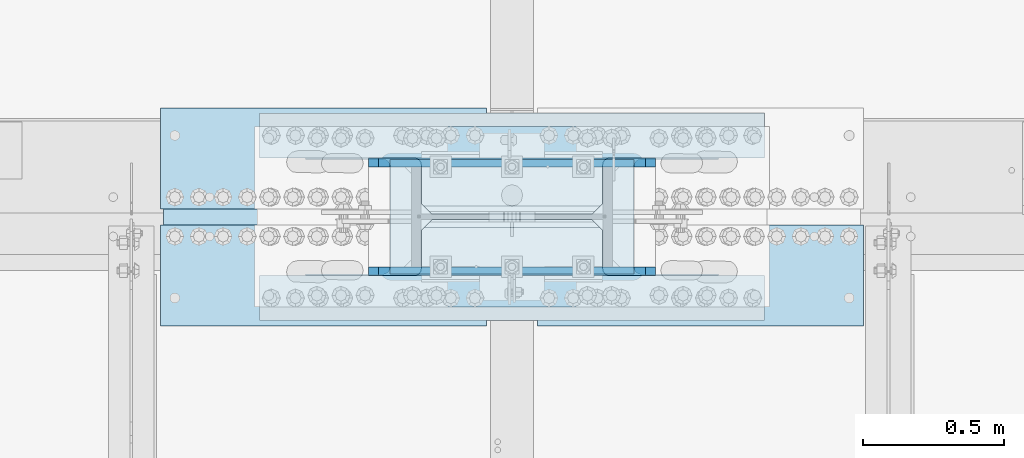
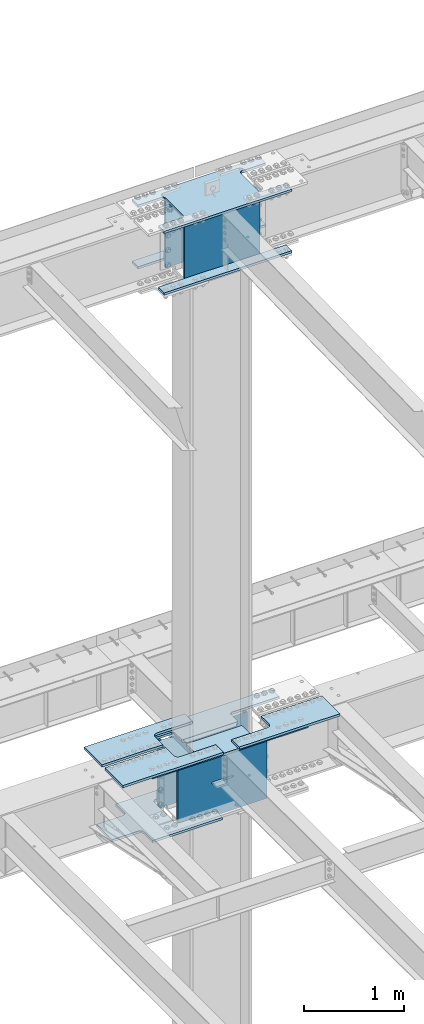
# One storey, part 1420 of 1763: 13 plates, 5 elements without a shape of their own.
"""IFC2X3 building model written with IfcOpenShell, lengths in millimetres."""

from ifc_helpers import new_model, si_unit, frame, origin_with_axes, place, context, subcontext, project, spatial, faceted_brep, material, type_object, element, aggregate, save


model = new_model("IFC2X3")

# Units and contexts
model_context = context("Model", 3, precision=1e-05, world=origin_with_axes())
body_context = subcontext(model_context, "Body", "Model", "MODEL_VIEW")
ifc_project = project(units=[si_unit("LENGTHUNIT", "METRE", prefix="MILLI"), si_unit("AREAUNIT", "SQUARE_METRE"), si_unit("VOLUMEUNIT", "CUBIC_METRE"), si_unit("MASSUNIT", "GRAM", prefix="KILO"), si_unit("TIMEUNIT", "SECOND"), si_unit("PLANEANGLEUNIT", "RADIAN"), si_unit("SOLIDANGLEUNIT", "STERADIAN"), si_unit("THERMODYNAMICTEMPERATUREUNIT", "DEGREE_CELSIUS"), si_unit("LUMINOUSINTENSITYUNIT", "LUMEN")], contexts=[model_context])

# Site, building, storey
site_placement = place(None, origin_with_axes())
site = spatial("IfcSite", under=ifc_project, at=site_placement, CompositionType="ELEMENT")
building_placement = place(site_placement, origin_with_axes())
building = spatial("IfcBuilding", under=site, at=building_placement, Name="Undefined", CompositionType="ELEMENT")
storey_placement = place(building_placement, origin_with_axes())
storey = spatial("IfcBuildingStorey", under=building, at=storey_placement, Name="Undefined", CompositionType="ELEMENT", Elevation=0.0)

# Assembly, plates
assembly_1_placement = place(storey_placement, origin_with_axes())
assembly_1 = element("IfcElementAssembly", 1, at=assembly_1_placement, inside=storey, Name="COLUMN", AssemblyPlace="NOTDEFINED", PredefinedType="RIGID_FRAME")
ifc_material_1 = material(Name="STEEL/A572-50")
plate_type_1 = type_object("IfcPlateType", PredefinedType="NOTDEFINED")
plate_1_placement = place(assembly_1_placement, frame((-71594.0997736984, 52111.275, 5180.0125), z_axis=(-1.0, 0.0, 0.0), x_axis=(0.0, -1.0, 0.0)))
plate_1 = element("IfcPlate", 2, at=plate_1_placement, type_object=plate_type_1, material=ifc_material_1, Name="PLATE", context=body_context, shape_type="Brep", body=[
    faceted_brep([(174.62499427794, 14.2875000000004, 574.67504882811), (174.62499427794, -14.2875000000004, 574.67504882811), (38.0999984741429, -14.2875000000004, 574.675024414115), (38.0999984741429, 14.2875000000004, 574.67504882811), (184.345153314032, 14.2875000000004, 572.741588982935), (184.345153314032, -14.2875000000004, 572.741588982935), (192.58550625034, 14.2875000000004, 567.23556118198), (192.58550625034, -14.2875000000004, 567.23556118198), (198.091534051295, 14.2875000000004, 558.995208245673), (198.091534051295, -14.2875000000004, 558.995208245673), (200.02499389647, 14.2875000000004, 549.27504920958), (200.02499389647, -14.2875000000004, 549.27504920958), (200.02499389647, 14.2875000000004, 0.0), (200.02499389647, -14.2875000000004, 0.0), (358.774993896484, 14.2875000000004, 0.0), (358.774993896484, -14.2875000000004, 0.0), (358.774993896484, -14.2875000000004, 1793.875), (358.774993896484, 14.2875000000004, 1793.875), (200.024993896448, 14.2875000000004, 1793.875), (200.024993896448, -14.2875000000004, 1793.87502441408), (200.024993896448, 14.2875000000004, 1244.59997520449), (200.024993896448, -14.2875000000004, 1244.59997520449), (198.091534051273, 14.2875000000004, 1234.8798161684), (198.091534051273, -14.2875000000004, 1234.8798161684), (192.585506250318, 14.2875000000004, 1226.63946323209), (192.585506250318, -14.2875000000004, 1226.63946323209), (184.345153314011, 14.2875000000004, 1221.13343543113), (184.345153314011, -14.2875000000004, 1221.13343543113), (174.624994277918, 14.2875000000004, 1219.19997558596), (174.624994277918, -14.2875000000004, 1219.19997558596), (38.0999984740847, 14.2875000000067, 1219.19997558596), (38.0999984740847, -14.2875000000004, 1219.19997558593), (28.5750003814683, 14.2875000000067, 1209.67497749336), (0.0, -14.2875000000004, 1181.09997711187), (0.0, -14.2875000000004, 612.775022888178), (28.575000381461, 14.2875000000004, 584.200037155169)], [[[0, 1, 2, 3]], [[1, 0, 4, 5]], [[5, 4, 6, 7]], [[7, 6, 8, 9]], [[9, 8, 10, 11]], [[11, 10, 12, 13]], [[14, 15, 13, 12]], [[16, 15, 14, 17]], [[16, 17, 18, 19]], [[19, 18, 20, 21]], [[21, 20, 22, 23]], [[23, 22, 24, 25]], [[25, 24, 26, 27]], [[27, 26, 28, 29]], [[29, 28, 30, 31]], [[31, 30, 32, 33]], [[2, 1, 5, 7, 9, 11, 13, 15, 16, 19, 21, 23, 25, 27, 29, 31, 33, 34]], [[3, 2, 34, 35]], [[30, 28, 26, 24, 22, 20, 18, 17, 14, 12, 10, 8, 6, 4, 0, 3, 35, 32]], [[34, 33, 32, 35]]]),
])
plate_2_placement = place(assembly_1_placement, frame((-71594.0997736984, 52130.325, 5180.0125), z_axis=(-1.0, 0.0, 0.0), x_axis=(0.0, 1.0, 0.0)))
plate_2 = element("IfcPlate", 3, at=plate_2_placement, type_object=plate_type_1, material=ifc_material_1, Name="PLATE", context=body_context, shape_type="Brep", body=[
    faceted_brep([(174.62499427794, 14.2875000000004, 574.67504882811), (174.62499427794, -14.2875000000004, 574.67504882811), (38.0999984741429, -14.2875000000004, 574.675024414115), (38.0999984741429, 14.2875000000004, 574.67504882811), (184.345153314032, 14.2875000000004, 572.741588982935), (184.345153314032, -14.2875000000004, 572.741588982935), (192.58550625034, 14.2875000000004, 567.23556118198), (192.58550625034, -14.2875000000004, 567.23556118198), (198.091534051295, 14.2875000000004, 558.995208245673), (198.091534051295, -14.2875000000004, 558.995208245673), (200.02499389647, 14.2875000000004, 549.27504920958), (200.02499389647, -14.2875000000004, 549.27504920958), (200.02499389647, 14.2875000000004, 0.0), (200.02499389647, -14.2875000000004, 0.0), (358.774993896484, 14.2875000000004, 0.0), (358.774993896484, -14.2875000000004, 0.0), (358.774993896484, -14.2875000000004, 1793.875), (358.774993896484, 14.2875000000004, 1793.875), (200.024993896448, 14.2875000000004, 1793.875), (200.024993896448, -14.2875000000004, 1793.87502441408), (200.024993896448, 14.2875000000004, 1244.59997520449), (200.024993896448, -14.2875000000004, 1244.59997520449), (198.091534051273, 14.2875000000004, 1234.8798161684), (198.091534051273, -14.2875000000004, 1234.8798161684), (192.585506250318, 14.2875000000004, 1226.63946323209), (192.585506250318, -14.2875000000004, 1226.63946323209), (184.345153314011, 14.2875000000004, 1221.13343543113), (184.345153314011, -14.2875000000004, 1221.13343543113), (174.624994277918, 14.2875000000004, 1219.19997558596), (174.624994277918, -14.2875000000004, 1219.19997558596), (38.0999984740847, 14.2875000000067, 1219.19997558596), (38.0999984740847, -14.2875000000004, 1219.19997558593), (28.5750000000116, -14.2875000000067, 1209.67497711188), (28.5750000000044, -14.2875000000004, 584.200022888232), (0.0, 14.2875000000004, 612.775022888178), (0.0, 14.2875000000004, 1181.09997711187)], [[[0, 1, 2, 3]], [[1, 0, 4, 5]], [[5, 4, 6, 7]], [[7, 6, 8, 9]], [[9, 8, 10, 11]], [[11, 10, 12, 13]], [[14, 15, 13, 12]], [[16, 15, 14, 17]], [[16, 17, 18, 19]], [[19, 18, 20, 21]], [[21, 20, 22, 23]], [[23, 22, 24, 25]], [[25, 24, 26, 27]], [[27, 26, 28, 29]], [[29, 28, 30, 31]], [[2, 1, 5, 7, 9, 11, 13, 15, 16, 19, 21, 23, 25, 27, 29, 31, 32, 33]], [[3, 2, 33, 34]], [[30, 28, 26, 24, 22, 20, 18, 17, 14, 12, 10, 8, 6, 4, 0, 3, 34, 35]], [[31, 30, 35, 32]], [[34, 33, 32, 35]]]),
])

# Assembly, plate
assembly_2_placement = place(storey_placement, origin_with_axes())
assembly_2 = element("IfcElementAssembly", 4, at=assembly_2_placement, inside=storey, Name="TOP PLATE", AssemblyPlace="NOTDEFINED", PredefinedType="RIGID_FRAME")
plate_3_placement = place(assembly_2_placement, frame((-71241.6747736984, 52092.225, 5208.5875), z_axis=(0.0, -1.0, 0.0), x_axis=(-1.0, 0.0, 0.0)))
plate_3 = element("IfcPlate", 5, at=plate_3_placement, type_object=plate_type_1, material=ifc_material_1, Name="TOP PLATE", context=body_context, shape_type="Brep", body=[
    faceted_brep([(0.0, -14.2875000000058, 0.0), (0.0, -14.2875000000004, 358.774993896484), (0.0, 14.2875000000004, 358.774993896484), (0.0, 14.2875000000058, 0.0), (1158.875, -14.2875000000004, 358.774993896484), (1158.875, 14.2875000000004, 358.774993896484), (1158.875, -14.2875000000004, 206.375), (1158.875, 14.2875000000004, 206.375), (746.124988555908, -14.2875000000004, 206.375), (746.124988555908, 14.2875000000004, 206.375), (729.114709695321, -14.2875000000004, 202.99144516205), (729.114709695321, 14.2875000000004, 202.99144516205), (714.694091592683, -14.2875000000004, 193.355896200279), (714.694091592683, 14.2875000000004, 193.355896200279), (705.058542630912, -14.2875000000004, 178.935278097655), (705.058542630912, 14.2875000000004, 178.935278097655), (701.674987792969, -14.2875000000004, 161.924999237061), (701.674987792969, 14.2875000000004, 161.924999237061), (701.674987792969, -14.2875000000004, 0.0), (701.674987792969, 14.2875000000004, 0.0)], [[[0, 1, 2, 3]], [[1, 4, 5, 2]], [[4, 6, 7, 5]], [[6, 8, 9, 7]], [[8, 10, 11, 9]], [[10, 12, 13, 11]], [[12, 14, 15, 13]], [[14, 16, 17, 15]], [[16, 18, 19, 17]], [[18, 0, 3, 19]], [[5, 7, 9, 11, 13, 15, 17, 19, 3, 2]], [[18, 16, 14, 12, 10, 8, 6, 4, 1, 0]]]),
])
aggregate(assembly_2, [plate_3])

assembly_3_placement = place(storey_placement, origin_with_axes())
assembly_3 = element("IfcElementAssembly", 6, at=assembly_3_placement, inside=storey, Name="TOP PLATE", AssemblyPlace="NOTDEFINED", PredefinedType="RIGID_FRAME")
plate_4_placement = place(assembly_3_placement, frame((-73740.3997736984, 52149.375, 5208.5875), z_axis=(0.0, 1.0, 0.0), x_axis=(1.0, 0.0, 0.0)))
plate_4 = element("IfcPlate", 7, at=plate_4_placement, type_object=plate_type_1, material=ifc_material_1, Name="TOP PLATE", context=body_context, shape_type="Brep", body=[
    faceted_brep([(0.0, -14.2875000000058, 0.0), (0.0, -14.2875000000004, 358.774993896484), (0.0, 14.2875000000004, 358.774993896484), (0.0, 14.2875000000058, 0.0), (1158.875, -14.2875000000004, 358.774993896484), (1158.875, 14.2875000000004, 358.774993896484), (1158.875, -14.2875000000004, 206.375), (1158.875, 14.2875000000004, 206.375), (746.124988555908, -14.2875000000004, 206.375), (746.124988555908, 14.2875000000004, 206.375), (729.114709695321, -14.2875000000004, 202.99144516205), (729.114709695321, 14.2875000000004, 202.99144516205), (714.694091592683, -14.2875000000004, 193.355896200279), (714.694091592683, 14.2875000000004, 193.355896200279), (705.058542630912, -14.2875000000004, 178.935278097655), (705.058542630912, 14.2875000000004, 178.935278097655), (701.674987792969, -14.2875000000004, 161.924999237061), (701.674987792969, 14.2875000000004, 161.924999237061), (701.674987792969, -14.2875000000004, 0.0), (701.674987792969, 14.2875000000004, 0.0)], [[[0, 1, 2, 3]], [[1, 4, 5, 2]], [[4, 6, 7, 5]], [[6, 8, 9, 7]], [[8, 10, 11, 9]], [[10, 12, 13, 11]], [[12, 14, 15, 13]], [[14, 16, 17, 15]], [[16, 18, 19, 17]], [[18, 0, 3, 19]], [[5, 7, 9, 11, 13, 15, 17, 19, 3, 2]], [[18, 16, 14, 12, 10, 8, 6, 4, 1, 0]]]),
])
aggregate(assembly_3, [plate_4])

assembly_4_placement = place(storey_placement, origin_with_axes())
assembly_4 = element("IfcElementAssembly", 8, at=assembly_4_placement, inside=storey, Name="TOP PLATE", AssemblyPlace="NOTDEFINED", PredefinedType="RIGID_FRAME")
plate_5_placement = place(assembly_4_placement, frame((-73038.7247736984, 52092.225, 5208.5875), z_axis=(0.0, -1.0, 0.0), x_axis=(-1.0, 0.0, 0.0)))
plate_5 = element("IfcPlate", 9, at=plate_5_placement, type_object=plate_type_1, material=ifc_material_1, Name="TOP PLATE", context=body_context, shape_type="Brep", body=[
    faceted_brep([(0.0, -14.2875000000058, 0.0), (0.0, -14.2875000000004, 161.924999237061), (0.0, 14.2875000000004, 161.924999237061), (0.0, 14.2875000000058, 0.0), (-3.38355483794294, -14.2875000000004, 178.935278097655), (-3.38355483794294, 14.2875000000004, 178.935278097655), (-13.0191037997138, -14.2875000000004, 193.355896200279), (-13.0191037997138, 14.2875000000004, 193.355896200279), (-27.4397219023522, -14.2875000000004, 202.99144516205), (-27.4397219023522, 14.2875000000004, 202.99144516205), (-44.4500007629395, -14.2875000000004, 206.375), (-44.4500007629395, 14.2875000000004, 206.375), (-457.200012207031, -14.2875000000004, 206.375), (-457.200012207031, 14.2875000000004, 206.375), (-457.200012207031, -14.2875000000004, 358.774993896484), (-457.200012207031, 14.2875000000004, 358.774993896484), (701.674987792969, -14.2875000000004, 358.774993896484), (701.674987792969, 14.2875000000004, 358.774993896484), (701.674987792969, -14.2875000000004, 0.0), (701.674987792969, 14.2875000000004, 0.0)], [[[0, 1, 2, 3]], [[1, 4, 5, 2]], [[4, 6, 7, 5]], [[6, 8, 9, 7]], [[8, 10, 11, 9]], [[10, 12, 13, 11]], [[12, 14, 15, 13]], [[14, 16, 17, 15]], [[16, 18, 19, 17]], [[18, 0, 3, 19]], [[5, 7, 9, 11, 13, 15, 17, 19, 3, 2]], [[18, 16, 14, 12, 10, 8, 6, 4, 1, 0]]]),
])
aggregate(assembly_4, [plate_5])

# Plate
plate_type_2 = type_object("IfcPlateType", PredefinedType="NOTDEFINED")
plate_6_placement = place(assembly_1_placement, frame((-73226.0497736984, 52441.4750002128, 11733.2124917654), z_axis=(1.0, 0.0, 0.0), x_axis=(0.0, -1.0, 0.0)))
plate_6 = element("IfcPlate", 10, at=plate_6_placement, type_object=plate_type_2, material=ifc_material_1, Name="PLATE", context=body_context, shape_type="Brep", body=[
    faceted_brep([(117.474998474121, -14.2875000000004, 1470.02502441406), (117.475000194951, -14.2875000000004, 1193.7999996006), (117.475000166465, 14.2875000000004, 1193.79999957211), (117.474998474121, 14.2875000000004, 1470.02502441406), (119.40846004527, -14.2875000000004, 1184.07984057001), (119.408460016784, 14.2875000000004, 1184.07984054153), (124.914487847418, -14.2875000000004, 1175.83948763979), (124.914487818933, 14.2875000000004, 1175.8394876113), (133.154840781528, -14.2875000000004, 1170.33345984345), (133.154840753043, 14.2875000000004, 1170.33345981497), (142.874999813481, -14.2875000000004, 1168.39999999999), (142.874999784995, 14.2875000000004, 1168.3999999715), (498.474994490825, -14.2875000000004, 1168.39999999997), (498.47499446234, 14.2875000000004, 1168.39999997149), (508.195153526918, -14.2875000000004, 1170.33345984515), (508.195153498433, 14.2875000000004, 1170.33345981667), (516.435506463225, -14.2875000000004, 1175.83948764611), (516.43550643474, 14.2875000000004, 1175.83948761762), (521.941534264181, -14.2875000000004, 1184.07984058242), (521.941534235695, 14.2875000000004, 1184.07984055393), (523.874994109356, -14.2875000000004, 1193.7999996185), (523.874994080878, 14.2875000000004, 1193.79999959002), (523.874994109356, -14.2875000000004, 1470.02503051757), (523.874994080878, 14.2875000000004, 1470.02502441406), (0.0, -14.2875000000058, 0.0), (-2.91038304567337e-11, -14.2875000000004, 1470.02502441406), (-2.91038304567337e-11, 14.2875000000004, 1470.02502441406), (0.0, 14.2875000000058, 0.0), (117.474975585938, -14.2875000000004, 0.0), (117.474975585938, 14.2875000000004, 0.0), (117.475000167673, 14.2875000000004, 276.224976013829), (117.475000196158, -14.2875000000004, 276.224975985344), (119.408460017992, 14.2875000000004, 285.945135044414), (119.408460046478, -14.2875000000004, 285.945135015929), (124.91448782014, 14.2875000000004, 294.185487974639), (124.914487848626, -14.2875000000004, 294.185487946153), (133.154840754258, 14.2875000000004, 299.691515770974), (133.154840782736, -14.2875000000004, 299.691515742488), (142.874999786203, 14.2875000000004, 301.624975614432), (142.874999814689, -14.2875000000004, 301.624975585954), (498.474994463555, 14.2875000000004, 301.624975614432), (498.474994492033, -14.2875000000004, 301.624975585954), (508.195153499641, 14.2875000000004, 299.691515769257), (508.195153528126, -14.2875000000004, 299.691515740778), (516.435506435948, 14.2875000000004, 294.185487968301), (516.435506464433, -14.2875000000004, 294.185487939816), (521.941534236903, 14.2875000000004, 285.945135031994), (521.941534265388, -14.2875000000004, 285.945135003509), (523.874994082085, 14.2875000000004, 276.224975995901), (523.874994110563, -14.2875000000004, 276.224975967423), (523.874994082085, 14.2875000000004, 1.45519152283669e-11), (523.874994110563, -14.2875000000004, 1.45519152283669e-11), (641.349975585938, 14.2875000000004, 1.45519152283669e-11), (641.349975585938, -14.2875000000004, 1.45519152283669e-11), (641.349975585938, -14.2875000000004, 1470.02502441406), (641.349975585938, 14.2875000000004, 1470.02502441406)], [[[0, 1, 2, 3]], [[4, 5, 2, 1]], [[6, 7, 5, 4]], [[8, 9, 7, 6]], [[10, 11, 9, 8]], [[12, 13, 11, 10]], [[14, 15, 13, 12]], [[16, 17, 15, 14]], [[18, 19, 17, 16]], [[20, 21, 19, 18]], [[22, 23, 21, 20]], [[24, 25, 26, 27]], [[28, 24, 27, 29]], [[28, 29, 30, 31]], [[31, 30, 32, 33]], [[33, 32, 34, 35]], [[35, 34, 36, 37]], [[37, 36, 38, 39]], [[39, 38, 40, 41]], [[41, 40, 42, 43]], [[43, 42, 44, 45]], [[45, 44, 46, 47]], [[47, 46, 48, 49]], [[49, 48, 50, 51]], [[52, 53, 51, 50]], [[54, 53, 52, 55]], [[18, 16, 14, 12, 10, 8, 6, 4, 1, 0, 25, 24, 28, 31, 33, 35, 37, 39, 41, 43, 45, 47, 49, 51, 53, 54, 22, 20]], [[25, 0, 3, 26]], [[55, 52, 50, 48, 46, 44, 42, 40, 38, 36, 34, 32, 30, 29, 27, 26, 3, 2, 5, 7, 9, 11, 13, 15, 17, 19, 21, 23]], [[54, 55, 23, 22]]]),
])

ifc_material_2 = material(Name="STEEL/A36")
plate_type_3 = type_object("IfcPlateType", PredefinedType="NOTDEFINED")
plate_7_placement = place(assembly_1_placement, frame((-73226.0497736984, 52324.0000017387, 10983.9124917654), z_axis=(0.0, 1.0, 0.0), x_axis=(1.0, 0.0, 0.0)))
plate_7 = element("IfcPlate", 11, at=plate_7_placement, type_object=plate_type_3, material=ifc_material_2, Name="PLATE", context=body_context, shape_type="Brep", body=[
    faceted_brep([(0.0, -14.2875000000058, 0.0), (0.0, -14.2875000000004, 117.474998474121), (0.0, 14.2875000000004, 117.474998474121), (0.0, 14.2875000000058, 0.0), (1470.02502441406, -14.2875000000004, 117.474998474121), (1470.02502441406, 14.2875000000004, 117.474998474121), (1470.02502441406, -14.2875000000004, 7.27595761418343e-12), (1470.02502441406, 14.2875000000004, 7.27595761418343e-12)], [[[0, 1, 2, 3]], [[1, 4, 5, 2]], [[4, 6, 7, 5]], [[6, 0, 3, 7]], [[5, 7, 3, 2]], [[6, 4, 1, 0]]]),
])

plate_8_placement = place(assembly_1_placement, frame((-73226.0497736984, 51917.6000002128, 10983.9124917654), z_axis=(1.0, 0.0, 0.0), x_axis=(0.0, -1.0, 0.0)))
plate_8 = element("IfcPlate", 12, at=plate_8_placement, type_object=plate_type_3, material=ifc_material_2, Name="PLATE", context=body_context, shape_type="Brep", body=[
    faceted_brep([(0.0, -14.2875000000058, 0.0), (-2.91038304567337e-11, -14.2875000000004, 1470.02502441406), (-2.91038304567337e-11, 14.2875000000004, 1470.02502441406), (0.0, 14.2875000000058, 0.0), (117.474998474121, -14.2875000000004, 1470.02502441406), (117.474998474121, 14.2875000000004, 1470.02502441406), (117.474975585938, -14.2875000000004, 0.0), (117.474975585938, 14.2875000000004, 0.0)], [[[0, 1, 2, 3]], [[1, 4, 5, 2]], [[4, 6, 7, 5]], [[6, 0, 3, 7]], [[5, 7, 3, 2]], [[6, 4, 1, 0]]]),
])

plate_type_4 = type_object("IfcPlateType", PredefinedType="NOTDEFINED")
plate_9_placement = place(assembly_1_placement, frame((-72057.6497736698, 52311.3, 11718.9249917654), z_axis=(0.0, 0.0, -1.0), x_axis=(-1.0, 0.0, 0.0)))
plate_9 = element("IfcPlate", 13, at=plate_9_placement, type_object=plate_type_4, material=ifc_material_1, Name="COVER PLATE", context=body_context, shape_type="Brep", body=[
    faceted_brep([(0.0, -12.6999999999971, -1.81898940354586e-12), (2.85799615085125e-08, -12.6999999999971, 825.5), (2.85799615085125e-08, 12.6999999999971, 825.5), (0.0, 12.6999999999971, -1.81898940354586e-12), (866.775024414062, -12.6999999999971, 825.5), (866.775024414062, 12.6999999999971, 825.5), (866.775024414062, -12.6999999999971, 0.0), (866.775024414062, 12.6999999999971, 0.0)], [[[0, 1, 2, 3]], [[1, 4, 5, 2]], [[4, 6, 7, 5]], [[6, 0, 3, 7]], [[5, 7, 3, 2]], [[6, 4, 1, 0]]]),
])

plate_10_placement = place(assembly_1_placement, frame((-72057.6497736698, 51930.3, 11718.9249917654), z_axis=(0.0, 0.0, -1.0), x_axis=(-1.0, 0.0, 0.0)))
plate_10 = element("IfcPlate", 14, at=plate_10_placement, type_object=plate_type_4, material=ifc_material_1, Name="COVER PLATE", context=body_context, shape_type="Brep", body=[
    faceted_brep([(0.0, -12.6999999999971, -1.81898940354586e-12), (2.85799615085125e-08, -12.6999999999971, 825.5), (2.85799615085125e-08, 12.6999999999971, 825.5), (0.0, 12.6999999999971, -1.81898940354586e-12), (866.775024414062, -12.6999999999971, 825.5), (866.775024414062, 12.6999999999971, 825.5), (866.775024414062, -12.6999999999971, 0.0), (866.775024414062, 12.6999999999971, 0.0)], [[[0, 1, 2, 3]], [[1, 4, 5, 2]], [[4, 6, 7, 5]], [[6, 0, 3, 7]], [[5, 7, 3, 2]], [[6, 4, 1, 0]]]),
])

# Assembly, plate
assembly_5_placement = place(storey_placement, origin_with_axes())
assembly_5 = element("IfcElementAssembly", 15, at=assembly_5_placement, inside=storey, Name="PLATE", AssemblyPlace="NOTDEFINED", PredefinedType="RIGID_FRAME")
plate_type_5 = type_object("IfcPlateType", PredefinedType="NOTDEFINED")
plate_11_placement = place(assembly_5_placement, frame((-72581.5247736984, 52489.1, 4405.3125), z_axis=(0.0, -1.0, 0.0), x_axis=(-1.0, 0.0, 0.0)))
plate_11 = element("IfcPlate", 16, at=plate_11_placement, type_object=plate_type_5, material=ifc_material_1, Name="PLATE", context=body_context, shape_type="Brep", body=[
    faceted_brep([(0.0, -14.2875000000058, 0.0), (0.0, -14.2875000000004, 133.350006103516), (0.0, 14.2875000000004, 133.350006103516), (0.0, 14.2875000000058, 0.0), (417.512512207031, -14.2875000000004, 133.350006103516), (417.512512207031, 14.2875000000004, 133.350006103516), (429.776624171282, -14.2875000000004, 135.292450613051), (429.776624171282, 14.2875000000004, 135.292450613051), (440.840239407393, -14.2875000000004, 140.929644139258), (440.840239407393, 14.2875000000004, 140.929644139258), (449.620374171282, -14.2875000000004, 149.709778903161), (449.620374171282, 14.2875000000004, 149.709778903161), (455.257567697496, -14.2875000000004, 160.773394139258), (455.257567697496, 14.2875000000004, 160.773394139258), (457.200012207031, -14.2875000000004, 173.037506103516), (457.200012207031, 14.2875000000004, 173.037506103516), (457.200012207031, -14.2875000000004, 563.5625), (457.200012207031, 14.2875000000004, 563.5625), (455.257567697496, -14.2875000000004, 575.826611964258), (455.257567697496, 14.2875000000004, 575.826611964258), (449.620374171282, -14.2875000000004, 586.890227200354), (449.620374171282, 14.2875000000004, 586.890227200354), (440.840239407393, -14.2875000000004, 595.670361964258), (440.840239407393, 14.2875000000004, 595.670361964258), (429.776624171282, -14.2875000000004, 601.307555490464), (429.776624171282, 14.2875000000004, 601.307555490464), (417.512512207031, -14.2875000000004, 603.25), (417.512512207031, 14.2875000000004, 603.25), (0.0, -14.2875000000004, 603.25), (0.0, 14.2875000000004, 603.25), (0.0, -14.2875000000004, 736.599975585938), (0.0, 14.2875000000004, 736.599975585938), (806.450012207031, -14.2875000000004, 736.599975585938), (806.450012207031, 14.2875000000004, 736.599975585938), (806.450012207031, -14.2875000000004, 563.5625), (806.450012207031, 14.2875000000004, 563.5625), (808.392456716567, -14.2875000000004, 551.298388035742), (808.392456716567, 14.2875000000004, 551.298388035742), (814.029650242781, -14.2875000000004, 540.234772799646), (814.029650242781, 14.2875000000004, 540.234772799646), (822.80978500667, -14.2875000000004, 531.454638035742), (822.80978500667, 14.2875000000004, 531.454638035742), (833.873400242781, -14.2875000000004, 525.817444509536), (833.873400242781, 14.2875000000004, 525.817444509536), (846.137512207031, -14.2875000000004, 523.875), (846.137512207031, 14.2875000000004, 523.875), (1149.34997558594, -14.2875000000004, 523.875), (1149.34997558594, 14.2875000000004, 523.875), (1149.34997558594, -14.2875000000004, 212.725006103516), (1149.34997558594, 14.2875000000004, 212.725006103516), (846.137512207031, -14.2875000000004, 212.725006103516), (846.137512207031, 14.2875000000004, 212.725006103516), (833.873400242781, -14.2875000000004, 210.78256159398), (833.873400242781, 14.2875000000004, 210.78256159398), (822.80978500667, -14.2875000000004, 205.145368067773), (822.80978500667, 14.2875000000004, 205.145368067773), (814.029650242781, -14.2875000000004, 196.36523330387), (814.029650242781, 14.2875000000004, 196.36523330387), (808.392456716567, -14.2875000000004, 185.301618067773), (808.392456716567, 14.2875000000004, 185.301618067773), (806.450012207031, -14.2875000000004, 173.037506103516), (806.450012207031, 14.2875000000004, 173.037506103516), (806.450012207031, -14.2875000000004, 0.0), (806.450012207031, 14.2875000000004, 0.0)], [[[0, 1, 2, 3]], [[1, 4, 5, 2]], [[4, 6, 7, 5]], [[6, 8, 9, 7]], [[8, 10, 11, 9]], [[10, 12, 13, 11]], [[12, 14, 15, 13]], [[14, 16, 17, 15]], [[16, 18, 19, 17]], [[18, 20, 21, 19]], [[20, 22, 23, 21]], [[22, 24, 25, 23]], [[24, 26, 27, 25]], [[26, 28, 29, 27]], [[28, 30, 31, 29]], [[30, 32, 33, 31]], [[32, 34, 35, 33]], [[34, 36, 37, 35]], [[36, 38, 39, 37]], [[38, 40, 41, 39]], [[40, 42, 43, 41]], [[42, 44, 45, 43]], [[44, 46, 47, 45]], [[46, 48, 49, 47]], [[48, 50, 51, 49]], [[50, 52, 53, 51]], [[52, 54, 55, 53]], [[54, 56, 57, 55]], [[56, 58, 59, 57]], [[58, 60, 61, 59]], [[60, 62, 63, 61]], [[62, 0, 3, 63]], [[5, 7, 9, 11, 13, 15, 17, 19, 21, 23, 25, 27, 29, 31, 33, 35, 37, 39, 41, 43, 45, 47, 49, 51, 53, 55, 57, 59, 61, 63, 3, 2]], [[62, 60, 58, 56, 54, 52, 50, 48, 46, 44, 42, 40, 38, 36, 34, 32, 30, 28, 26, 24, 22, 20, 18, 16, 14, 12, 10, 8, 6, 4, 1, 0]]]),
])
aggregate(assembly_5, [plate_11])

# Plate
plate_type_6 = type_object("IfcPlateType", PredefinedType="NOTDEFINED")
plate_12_placement = place(assembly_1_placement, frame((-73000.6247736983, 51927.125, 5165.725), z_axis=(0.0, 0.0, -1.0), x_axis=(1.0, 0.0, 0.0)))
plate_12 = element("IfcPlate", 17, at=plate_12_placement, type_object=plate_type_6, material=ifc_material_1, Name="COVER PLATE", context=body_context, shape_type="Brep", body=[
    faceted_brep([(984.249999237072, 15.8750000000218, 31.7499999999918), (984.249999237072, -15.875, 0.0), (796.9250236511, -15.875, 0.0), (796.9250236511, 15.8750000000073, 31.7499999999991), (984.249999237072, 15.875, 0.0), (34.9249992370751, 15.8750000000218, 31.7499999999918), (34.9249992370751, -15.875, 0.0), (34.9249992370751, 15.875, 0.0), (222.250023651097, 15.8750000000218, 31.7499999999918), (222.250023651097, -15.875, 0.0), (0.0, -15.875, 0.0), (0.0, 15.875, 0.0), (0.0, -15.875, 822.324951171875), (0.0, 15.875, 822.324951171875), (1019.17498779297, -15.875, 822.324951171875), (1019.17498779297, 15.875, 822.324951171875), (1019.17498779297, -15.875, 0.0), (1019.17498779297, 15.875, 0.0), (631.745205739557, 15.875, 423.782722524225), (628.140051213893, 15.875, 426.191609764667), (623.88748149875, 15.875, 427.037498474155), (395.287500190767, 15.875, 427.037498474155), (391.034930475624, 15.875, 426.191609764667), (387.42977594996, 15.875, 423.782722524225), (385.020888709521, 15.875, 420.177567998568), (384.175000000032, 15.875, 415.925000190768), (385.020888709521, 15.875, 411.67243047562), (387.42977594996, 15.875, 408.067275949962), (391.034930475624, 15.875, 405.65838870952), (395.287500190767, 15.875, 404.812500000033), (623.88748149875, 15.875, 404.812500000009), (628.140051213893, 15.875, 405.658388709496), (631.745205739557, 15.875, 408.067275949938), (634.154092979996, 15.875, 411.672430475595), (634.999981689485, 15.875, 415.92499828342), (634.154092979996, 15.875, 420.177567998568), (634.154092979996, -15.875, 420.177567998568), (634.999981689485, -15.875, 415.92499828342), (631.745205739557, -15.875, 423.782722524225), (628.140051213893, -15.875, 426.191609764667), (623.88748149875, -15.875, 427.037498474155), (395.287500190767, -15.875, 427.037498474155), (391.034930475624, -15.875, 426.191609764667), (387.42977594996, -15.875, 423.782722524225), (385.020888709521, -15.875, 420.177567998568), (384.175000000032, -15.875, 415.925000190768), (385.020888709521, -15.875, 411.67243047562), (387.42977594996, -15.875, 408.067275949962), (391.034930475624, -15.875, 405.65838870952), (395.287500190767, -15.875, 404.812500000033), (623.88748149875, -15.875, 404.812500000009), (628.140051213893, -15.875, 405.658388709496), (631.745205739557, -15.875, 408.067275949938), (634.154092979996, -15.875, 411.672430475595)], [[[0, 1, 2, 3]], [[4, 1, 0]], [[5, 6, 7]], [[8, 9, 6, 5]], [[10, 11, 7, 6]], [[10, 12, 13, 11]], [[12, 14, 15, 13]], [[14, 16, 17, 15]], [[17, 16, 1, 4]], [[8, 5, 7, 11, 13, 15, 17, 4, 0, 3], [18, 19, 20, 21, 22, 23, 24, 25, 26, 27, 28, 29, 30, 31, 32, 33, 34, 35]], [[36, 35, 34, 37]], [[38, 18, 35, 36]], [[39, 19, 18, 38]], [[40, 20, 19, 39]], [[41, 21, 20, 40]], [[42, 22, 21, 41]], [[43, 23, 22, 42]], [[44, 24, 23, 43]], [[45, 25, 24, 44]], [[46, 26, 25, 45]], [[47, 27, 26, 46]], [[48, 28, 27, 47]], [[49, 29, 28, 48]], [[50, 30, 29, 49]], [[51, 31, 30, 50]], [[52, 32, 31, 51]], [[53, 33, 32, 52]], [[37, 34, 33, 53]], [[16, 14, 12, 10, 6, 9, 2, 1], [52, 51, 50, 49, 48, 47, 46, 45, 44, 43, 42, 41, 40, 39, 38, 36, 37, 53]], [[3, 2, 9, 8]]]),
])

plate_13_placement = place(assembly_1_placement, frame((-73000.6247736983, 52314.475, 5165.725), z_axis=(0.0, 0.0, -1.0), x_axis=(1.0, 0.0, 0.0)))
plate_13 = element("IfcPlate", 18, at=plate_13_placement, type_object=plate_type_6, material=ifc_material_1, Name="COVER PLATE", context=body_context, shape_type="Brep", body=[
    faceted_brep([(984.249999237072, -15.8749999999927, 31.7500000000036), (984.249999237072, 15.875, 0.0), (984.249999237072, -15.875, 0.0), (796.925023651071, -15.8750000000218, 31.7500000000109), (796.925023651071, 15.875, 0.0), (34.9249992370751, -15.875, 0.0), (34.9249992370751, 15.875, 0.0), (34.9249992370605, -15.8749999999927, 31.7500000000036), (222.250023651082, -15.8749999999927, 31.7500000000036), (222.250023651082, 15.875, 0.0), (0.0, -15.875, 0.0), (0.0, 15.875, 0.0), (0.0, -15.875, 822.324951171875), (0.0, 15.875, 822.324951171875), (1019.17498779297, -15.875, 822.324951171875), (1019.17498779297, 15.875, 822.324951171875), (1019.17498779297, -15.875, 0.0), (1019.17498779297, 15.875, 0.0), (631.745205739557, 15.875, 423.782722524225), (628.140051213893, 15.875, 426.191609764667), (623.88748149875, 15.875, 427.037498474155), (395.287500190767, 15.875, 427.037498474155), (391.034930475624, 15.875, 426.191609764667), (387.42977594996, 15.875, 423.782722524225), (385.020888709521, 15.875, 420.177567998568), (384.175000000032, 15.875, 415.925000190768), (385.020888709521, 15.875, 411.67243047562), (387.42977594996, 15.875, 408.067275949962), (391.034930475624, 15.875, 405.65838870952), (395.287500190767, 15.875, 404.812500000033), (623.88748149875, 15.875, 404.812500000009), (628.140051213893, 15.875, 405.658388709496), (631.745205739557, 15.875, 408.067275949938), (634.154092979996, 15.875, 411.672430475595), (634.999981689485, 15.875, 415.92499828342), (634.154092979996, 15.875, 420.177567998568), (634.154092979996, -15.875, 420.177567998568), (634.999981689485, -15.875, 415.92499828342), (631.745205739557, -15.875, 423.782722524225), (628.140051213893, -15.875, 426.191609764667), (623.88748149875, -15.875, 427.037498474155), (395.287500190767, -15.875, 427.037498474155), (391.034930475624, -15.875, 426.191609764667), (387.42977594996, -15.875, 423.782722524225), (385.020888709521, -15.875, 420.177567998568), (384.175000000032, -15.875, 415.925000190768), (385.020888709521, -15.875, 411.67243047562), (387.42977594996, -15.875, 408.067275949962), (391.034930475624, -15.875, 405.65838870952), (395.287500190767, -15.875, 404.812500000033), (623.88748149875, -15.875, 404.812500000009), (628.140051213893, -15.875, 405.658388709496), (631.745205739557, -15.875, 408.067275949938), (634.154092979996, -15.875, 411.672430475595)], [[[0, 1, 2]], [[3, 4, 1, 0]], [[5, 6, 7]], [[8, 7, 6, 9]], [[8, 9, 4, 3]], [[10, 11, 6, 5]], [[10, 12, 13, 11]], [[12, 14, 15, 13]], [[14, 16, 17, 15]], [[17, 16, 2, 1]], [[9, 6, 11, 13, 15, 17, 1, 4], [18, 19, 20, 21, 22, 23, 24, 25, 26, 27, 28, 29, 30, 31, 32, 33, 34, 35]], [[36, 35, 34, 37]], [[38, 18, 35, 36]], [[39, 19, 18, 38]], [[40, 20, 19, 39]], [[41, 21, 20, 40]], [[42, 22, 21, 41]], [[43, 23, 22, 42]], [[44, 24, 23, 43]], [[45, 25, 24, 44]], [[46, 26, 25, 45]], [[47, 27, 26, 46]], [[48, 28, 27, 47]], [[49, 29, 28, 48]], [[50, 30, 29, 49]], [[51, 31, 30, 50]], [[52, 32, 31, 51]], [[53, 33, 32, 52]], [[37, 34, 33, 53]], [[16, 14, 12, 10, 5, 7, 8, 3, 0, 2], [52, 51, 50, 49, 48, 47, 46, 45, 44, 43, 42, 41, 40, 39, 38, 36, 37, 53]]]),
])

aggregate(assembly_1, [plate_1, plate_2, plate_7, plate_8, plate_6, plate_9, plate_10, plate_12, plate_13])

save(model, "model.ifc")
